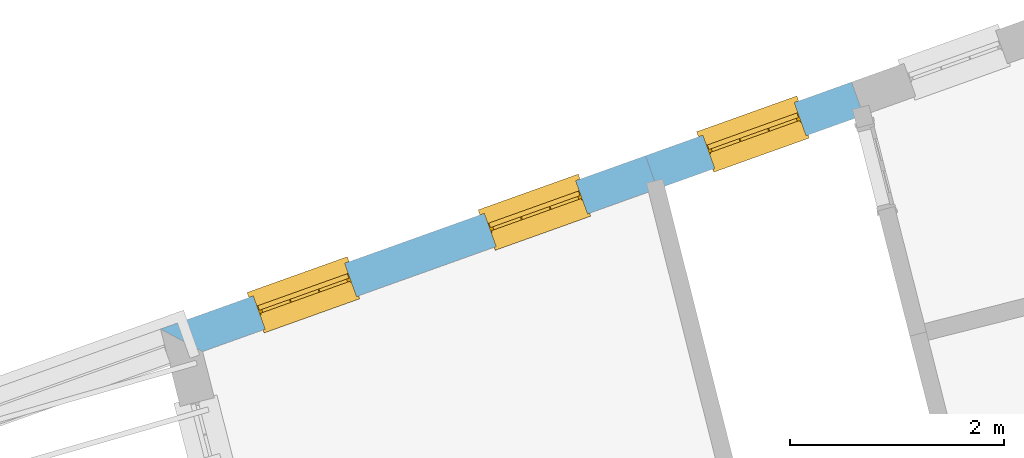
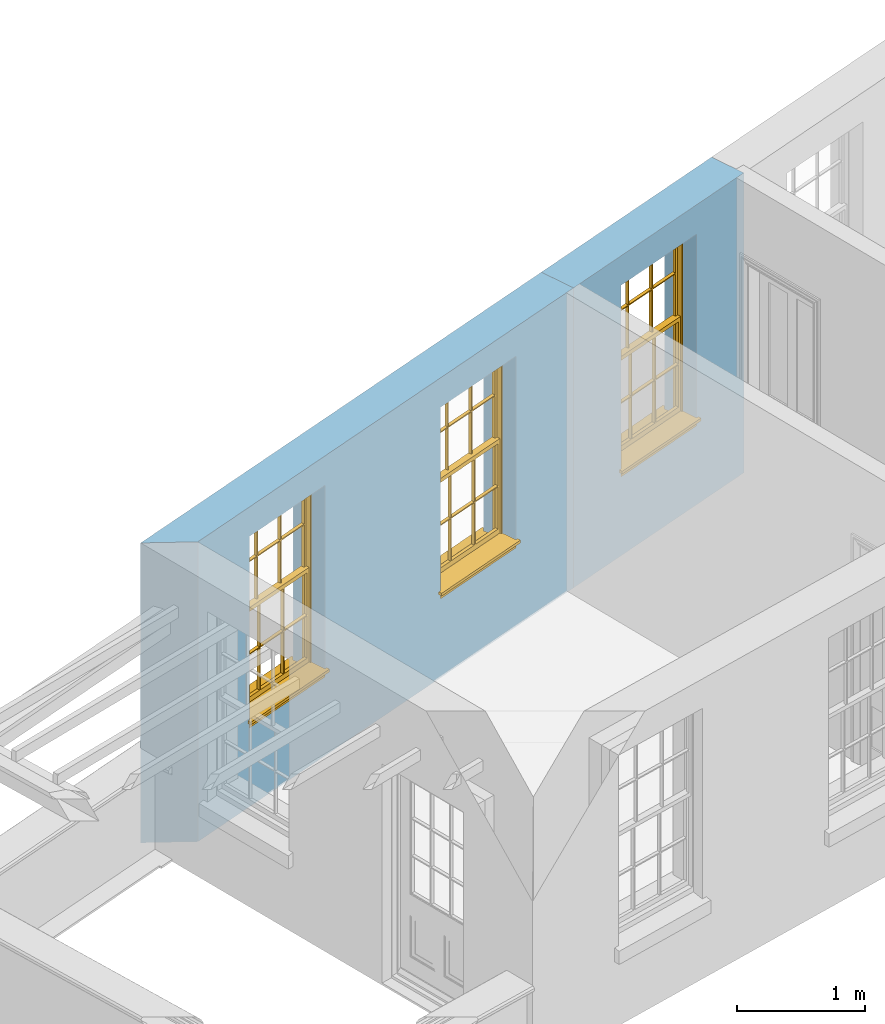
# One storey, part 4 of 11: 3 windows, 3 openings, plus 2 elements that do not belong to this part.
"""IFC2X3 building model written with IfcOpenShell, lengths in metres."""

from ifc_helpers import new_model, si_unit, frame, origin, place, context, subcontext, project, spatial, polyline, outline, extrude, faceted_brep, material, layer, layer_set, layer_usage, element, fill, save


model = new_model("IFC2X3")

# Units and contexts
model_context = context("Model", 3, world=origin())
body_context = subcontext(model_context, "Body", "Model", "MODEL_VIEW")
ifc_project = project(units=[si_unit("PLANEANGLEUNIT", "RADIAN"), si_unit("MASSUNIT", "GRAM", prefix="KILO"), si_unit("FORCEUNIT", "NEWTON", prefix="KILO"), si_unit("LENGTHUNIT", "METRE")], contexts=[model_context])

# Site, building, storey
site_placement = place(None, origin())
site = spatial("IfcSite", under=ifc_project, at=site_placement, CompositionType="ELEMENT")
building_placement = place(None, origin())
building = spatial("IfcBuilding", under=site, at=building_placement, Name="Building plot-13", CompositionType="ELEMENT")
storey_placement = place(None, frame((0.0, 0.0, 6.7)))
storey = spatial("IfcBuildingStorey", under=building, at=storey_placement, Name="Floor 1", CompositionType="ELEMENT", Elevation=6.7)

# Wall, opening, window
ifc_material = material(Name="Masonry")
ifc_layer = layer(ifc_material, 0.33, ventilated=False)
ifc_layer_set = layer_set([ifc_layer], Name="My Wall")
ifc_layer_usage = layer_usage(ifc_layer_set, "AXIS2", "NEGATIVE", 0.08)
wall_1_placement = place(storey_placement, origin())
wall_1 = element("IfcWallStandardCase", 1, at=wall_1_placement, inside=storey, material=ifc_layer_usage, Name="exterior", context=body_context, shape_type="SweptSolid", body=[
    extrude(outline(polyline([(72.090338058868, 49.7513205451126), (71.9792289491637, 50.0620531725284), (70.0510857180657, 49.3726042415572), (70.16219482777, 49.0618716141414), (72.090338058868, 49.7513205451126)])), origin(), (0.0, 0.0, 1.0), 2.85),
])
opening_1_placement = place(storey_placement, frame((0.0, 0.0, 0.75)))
opening_1 = element("IfcOpeningElement", 2, at=opening_1_placement, cuts=wall_1, Name="Opening", ObjectType="Opening", context=body_context, shape_type="SweptSolid", body=[
    extrude(outline(polyline([(71.4435917138395, 49.870524600726), (70.5867229533899, 49.5641328133596), (70.6978320630942, 49.2534001859438), (71.5547008235438, 49.5597919733102), (71.4435917138395, 49.870524600726)])), origin(), (0.0, 0.0, 1.0), 1.82),
])
window_1_placement = place(storey_placement, frame((71.5277652817973, 49.635121095108, 0.75), z_axis=(0.0, 0.0, 1.0), x_axis=(-0.856868760449586, -0.306391787366422, 0.0)))
window_1 = element("IfcWindow", 3, at=window_1_placement, inside=storey, Name="circulation outside window", OverallHeight=1.82, OverallWidth=0.91, context=body_context, shape_type="Brep", held_by="IfcProductRepresentation", body=[
    faceted_brep([(0.033125, -0.105, 0.975209), (0.01, -0.105, 0.975209), (0.033125, -0.105, 1.376042), (0.876875, -0.105, 0.975209), (0.876875, -0.105, 1.376042), (0.9, -0.105, 0.975209), (0.876875, -0.105, 1.386042), (0.876875, -0.105, 1.786875), (0.9, -0.105, 1.81), (0.033125, -0.105, 1.786875), (0.033125, -0.105, 1.386042), (0.01, -0.105, 1.81), (0.876875, -0.135, 1.376042), (0.876875, -0.135, 0.975209), (0.9, -0.135, 0.937083), (0.033125, -0.135, 1.786875), (0.01, -0.135, 1.81), (0.033125, -0.135, 1.386042), (0.01, -0.135, 0.937083), (0.033125, -0.135, 0.975209), (0.033125, -0.135, 1.376042), (0.876875, -0.135, 1.786875), (0.876875, -0.135, 1.386042), (0.9, -0.135, 1.81), (0.033125, -0.105, 0.937083), (0.01, -0.105, 0.937083), (0.033125, -0.105, 0.53625), (0.876875, -0.105, 0.937083), (0.876875, -0.105, 0.53625), (0.9, -0.105, 0.937083), (0.876875, -0.105, 0.52625), (0.876875, -0.105, 0.125417), (0.9, -0.105, 0.077167), (0.033125, -0.105, 0.125417), (0.033125, -0.105, 0.52625), (0.01, -0.105, 0.077167), (-0.0425, -0.25, 0.01), (-0.0425, -0.3, 0.001667), (0.0, -0.25, 0.01), (0.9525, -0.25, 0.01), (0.91, -0.25, 0.01), (0.9525, -0.3, 0.001667), (-0.02, 0.08, 0.077167), (0.0, 0.08, 0.077167), (-0.02, 0.11, 0.077167), (0.0, -0.06, 0.077167), (0.01, -0.06, 0.077167), (0.91, -0.06, 0.077167), (0.91, 0.08, 0.077167), (0.9, -0.06, 0.077167), (0.93, 0.08, 0.077167), (0.93, 0.11, 0.077167), (0.01, -0.075, 0.975209), (0.9, -0.075, 0.975209), (0.876875, -0.075, 0.125417), (0.876875, -0.075, 0.52625), (0.9, -0.075, 0.077167), (0.876875, -0.075, 0.53625), (0.876875, -0.075, 0.937083), (0.033125, -0.075, 0.125417), (0.01, -0.075, 0.077167), (0.033125, -0.075, 0.52625), (0.033125, -0.075, 0.937083), (0.033125, -0.075, 0.53625), (-0.02, 0.08, 0.052167), (-0.02, 0.11, 0.052167), (0.93, 0.11, 0.052167), (0.93, 0.08, 0.052167), (0.91, 0.08, 0.052167), (0.0, 0.08, 0.052167), (0.91, -0.15, 0.026667), (0.0, -0.15, 0.026667), (-0.0425, -0.3, -0.123333), (0.9525, -0.3, -0.123333), (-0.0425, -0.25, -0.123333), (0.9525, -0.25, -0.123333), (0.01, -0.06, 1.81), (0.9, -0.06, 1.81), (0.0, -0.06, 1.82), (0.91, -0.06, 1.82), (0.01, -0.15, 0.077167), (0.9, -0.15, 0.077167), (0.592292, -0.105, 0.125417), (0.592292, -0.075, 0.125417), (0.317708, -0.075, 0.125417), (0.317708, -0.105, 0.125417), (0.592292, -0.105, 0.53625), (0.317708, -0.105, 0.53625), (0.317708, -0.105, 0.52625), (0.592292, -0.105, 0.52625), (0.592292, -0.075, 0.53625), (0.317708, -0.075, 0.53625), (0.592292, -0.135, 1.386042), (0.592292, -0.105, 1.386042), (0.317708, -0.105, 1.386042), (0.317708, -0.135, 1.386042), (0.317708, -0.135, 1.376042), (0.592292, -0.135, 1.376042), (0.317708, -0.105, 1.376042), (0.592292, -0.105, 1.376042), (0.602292, -0.135, 1.376042), (0.592292, -0.135, 0.975209), (0.602292, -0.135, 0.975209), (0.602292, -0.105, 0.975209), (0.592292, -0.105, 0.975209), (0.602292, -0.105, 1.376042), (0.602292, -0.075, 0.53625), (0.602292, -0.105, 0.53625), (0.317708, -0.075, 0.52625), (0.307708, -0.075, 0.125417), (0.307708, -0.075, 0.52625), (0.602292, -0.075, 0.52625), (0.602292, -0.075, 0.125417), (0.592292, -0.075, 0.52625), (0.307708, -0.075, 0.53625), (0.317708, -0.075, 0.937083), (0.307708, -0.075, 0.937083), (0.602292, -0.075, 0.937083), (0.592292, -0.075, 0.937083), (0.307708, -0.105, 0.52625), (0.307708, -0.105, 0.125417), (0.307708, -0.105, 0.53625), (0.307708, -0.105, 0.937083), (0.592292, -0.105, 0.937083), (0.317708, -0.105, 0.937083), (0.602292, -0.105, 0.937083), (0.602292, -0.105, 0.52625), (0.602292, -0.105, 0.125417), (0.307708, -0.135, 1.386042), (0.307708, -0.135, 1.376042), (0.307708, -0.135, 0.975209), (0.317708, -0.135, 0.975209), (0.317708, -0.135, 1.786875), (0.307708, -0.135, 1.786875), (0.602292, -0.135, 1.786875), (0.592292, -0.135, 1.786875), (0.602292, -0.135, 1.386042), (0.602292, -0.105, 1.386042), (0.307708, -0.105, 1.386042), (0.307708, -0.105, 1.786875), (0.317708, -0.105, 1.786875), (0.592292, -0.105, 1.786875), (0.602292, -0.105, 1.786875), (0.307708, -0.105, 1.376042), (0.317708, -0.105, 0.975209), (0.307708, -0.105, 0.975209), (0.91, -0.15, 1.82), (0.9, -0.15, 1.81), (0.01, -0.15, 1.81), (0.0, -0.15, 1.82), (0.91, -0.25, 0.0), (0.0, -0.25, 0.0), (0.91, 0.08, 0.0), (0.0, 0.08, 0.0)], [[[0, 1, 2]], [[3, 4, 5]], [[6, 7, 8]], [[9, 10, 11]], [[12, 13, 14]], [[15, 16, 17]], [[18, 19, 20]], [[21, 22, 23]], [[24, 25, 26]], [[27, 28, 29]], [[30, 31, 32]], [[33, 34, 35]], [[14, 27, 29]], [[25, 24, 18]], [[36, 37, 38]], [[39, 40, 41]], [[42, 43, 44]], [[45, 46, 43]], [[47, 48, 49]], [[50, 51, 48]], [[1, 0, 52]], [[5, 53, 3]], [[54, 55, 56]], [[57, 58, 53]], [[59, 60, 61]], [[62, 63, 52]], [[48, 43, 46, 49]], [[51, 44, 43, 48]], [[64, 42, 44, 65]], [[65, 44, 51, 66]], [[66, 51, 50, 67]], [[65, 66, 68, 69]], [[60, 56, 49, 46]], [[70, 71, 38, 40]], [[37, 41, 40, 38]], [[37, 72, 73, 41]], [[74, 75, 73, 72]], [[8, 11, 76, 77]], [[76, 78, 79, 77]], [[32, 35, 80, 81]], [[81, 80, 71, 70]], [[82, 83, 84, 85]], [[86, 87, 88, 89]], [[86, 90, 91, 87]], [[92, 93, 94, 95]], [[92, 95, 96, 97]], [[96, 98, 99, 97]], [[100, 97, 101, 102]], [[103, 104, 99, 105]], [[97, 99, 104, 101]], [[102, 103, 105, 100]], [[28, 57, 106, 107]], [[108, 84, 109, 110]], [[111, 112, 83, 113]], [[114, 110, 61, 63]], [[90, 113, 108, 91]], [[115, 91, 114, 116]], [[117, 106, 90, 118]], [[111, 106, 57, 55]], [[119, 110, 109, 120]], [[34, 61, 110, 119]], [[89, 113, 83, 82]], [[88, 108, 113, 89]], [[85, 84, 108, 88]], [[121, 114, 63, 26]], [[122, 116, 114, 121]], [[123, 118, 90, 86]], [[87, 91, 115, 124]], [[107, 106, 117, 125]], [[126, 111, 55, 30]], [[127, 112, 111, 126]], [[126, 30, 28, 107]], [[88, 119, 120, 85]], [[126, 89, 82, 127]], [[125, 123, 86, 107]], [[121, 26, 34, 119]], [[124, 122, 121, 87]], [[128, 17, 20, 129]], [[96, 129, 130, 131]], [[132, 133, 128, 95]], [[134, 135, 92, 136]], [[100, 12, 22, 136]], [[137, 6, 4, 105]], [[94, 138, 139, 140]], [[137, 93, 141, 142]], [[99, 98, 94, 93]], [[143, 2, 10, 138]], [[144, 145, 143, 98]], [[129, 143, 145, 130]], [[20, 2, 143, 129]], [[131, 144, 98, 96]], [[128, 138, 10, 17]], [[133, 139, 138, 128]], [[135, 141, 93, 92]], [[95, 94, 140, 132]], [[22, 6, 137, 136]], [[136, 137, 142, 134]], [[100, 105, 4, 12]], [[107, 86, 89, 126]], [[106, 111, 113, 90]], [[91, 108, 110, 114]], [[87, 121, 119, 88]], [[97, 100, 136, 92]], [[129, 96, 95, 128]], [[98, 143, 138, 94]], [[105, 99, 93, 137]], [[131, 101, 104, 144]], [[124, 115, 118, 123]], [[132, 140, 141, 135]], [[120, 109, 59, 33]], [[15, 9, 139, 133]], [[134, 142, 7, 21]], [[31, 54, 112, 127]], [[36, 74, 72, 37]], [[39, 41, 73, 75]], [[18, 14, 101, 131]], [[23, 16, 132, 135]], [[83, 56, 60, 84]], [[52, 53, 118, 115]], [[53, 52, 144, 104]], [[11, 8, 141, 140]], [[14, 18, 124, 123]], [[2, 1, 11, 10]], [[8, 5, 4, 6]], [[57, 53, 56, 55]], [[60, 52, 63, 61]], [[26, 25, 35, 34]], [[32, 29, 28, 30]], [[14, 23, 22, 12]], [[18, 20, 17, 16]], [[19, 0, 2, 20]], [[17, 10, 9, 15]], [[12, 4, 3, 13]], [[21, 7, 6, 22]], [[27, 58, 57, 28]], [[30, 55, 54, 31]], [[33, 59, 61, 34]], [[26, 63, 62, 24]], [[5, 8, 77, 53]], [[76, 11, 1, 52]], [[46, 45, 78, 76]], [[49, 77, 79, 47]], [[70, 146, 147, 81]], [[71, 80, 148, 149]], [[19, 130, 145, 0]], [[102, 13, 3, 103]], [[116, 122, 24, 62]], [[29, 32, 81, 14]], [[80, 35, 25, 18]], [[60, 46, 76, 52]], [[77, 49, 56, 53]], [[23, 14, 81, 147]], [[16, 148, 80, 18]], [[35, 85, 120]], [[120, 33, 35]], [[127, 82, 32]], [[32, 31, 127]], [[32, 82, 85, 35]], [[102, 101, 14]], [[14, 13, 102]], [[18, 131, 130]], [[130, 19, 18]], [[134, 21, 23]], [[23, 135, 134]], [[16, 15, 133]], [[133, 132, 16]], [[11, 140, 139]], [[139, 9, 11]], [[142, 141, 8]], [[8, 7, 142]], [[23, 147, 148, 16]], [[146, 149, 148, 147]], [[52, 115, 116]], [[116, 62, 52]], [[118, 53, 117]], [[58, 117, 53]], [[27, 125, 117, 58]], [[56, 83, 112]], [[112, 54, 56]], [[109, 84, 60]], [[60, 59, 109]], [[125, 27, 14]], [[14, 123, 125]], [[122, 124, 18]], [[18, 24, 122]], [[145, 144, 52]], [[52, 0, 145]], [[103, 3, 53]], [[53, 104, 103]], [[79, 78, 149, 146]], [[78, 45, 71, 149]], [[146, 70, 47, 79]], [[150, 75, 74, 151]], [[68, 66, 67]], [[48, 68, 67, 50]], [[69, 64, 65]], [[42, 64, 69, 43]], [[69, 68, 152, 153]], [[70, 68, 48, 47]], [[150, 152, 68, 70]], [[43, 69, 71, 45]], [[69, 153, 151, 71]], [[152, 150, 151, 153]], [[38, 151, 74, 36]], [[71, 151, 38]], [[39, 75, 150, 40]], [[40, 150, 70]]]),
])
fill(opening_1, window_1)

# Wall, openings, windows
wall_2_placement = place(storey_placement, origin())
wall_2 = element("IfcWallStandardCase", 4, at=wall_2_placement, inside=storey, material=ifc_layer_usage, Name="exterior", context=body_context, shape_type="SweptSolid", body=[
    extrude(outline(polyline([(70.16219482777, 49.0618716141414), (70.0510857180657, 49.3726042415572), (65.5129266056267, 47.7498882014907), (65.9065629771408, 47.5401792508866), (70.16219482777, 49.0618716141414)])), origin(), (0.0, 0.0, 1.0), 2.85),
])
opening_2_placement = place(storey_placement, frame((0.0, 0.0, 0.75)))
opening_2 = element("IfcOpeningElement", 5, at=opening_2_placement, cuts=wall_2, Name="Opening", ObjectType="Opening", context=body_context, shape_type="SweptSolid", body=[
    extrude(outline(polyline([(69.3984892712811, 49.1392543973472), (68.5416205108315, 48.8328626099808), (68.6527296205358, 48.522129982565), (69.5095983809854, 48.8285217699314), (69.3984892712811, 49.1392543973472)])), origin(), (0.0, 0.0, 1.0), 1.82),
])
opening_3_placement = place(storey_placement, frame((0.0, 0.0, 0.75)))
opening_3 = element("IfcOpeningElement", 6, at=opening_3_placement, cuts=wall_2, Name="Opening", ObjectType="Opening", context=body_context, shape_type="SweptSolid", body=[
    extrude(outline(polyline([(67.2364276172623, 48.3661629215608), (66.3795588568127, 48.0597711341944), (66.490667966517, 47.7490385067786), (67.3475367269666, 48.055430294145), (67.2364276172623, 48.3661629215608)])), origin(), (0.0, 0.0, 1.0), 1.82),
])
window_2_placement = place(storey_placement, frame((69.4826628392389, 48.9038508917292, 0.75), z_axis=(0.0, 0.0, 1.0), x_axis=(-0.856868760449572, -0.306391787366422, 0.0)))
window_2 = element("IfcWindow", 7, at=window_2_placement, inside=storey, Name="bedroom outside window", OverallHeight=1.82, OverallWidth=0.91, context=body_context, shape_type="Brep", held_by="IfcProductRepresentation", body=[
    faceted_brep([(0.033125, -0.105, 0.975209), (0.01, -0.105, 0.975209), (0.033125, -0.105, 1.376042), (0.876875, -0.105, 0.975209), (0.876875, -0.105, 1.376042), (0.9, -0.105, 0.975209), (0.876875, -0.105, 1.386042), (0.876875, -0.105, 1.786875), (0.9, -0.105, 1.81), (0.033125, -0.105, 1.786875), (0.033125, -0.105, 1.386042), (0.01, -0.105, 1.81), (0.876875, -0.135, 1.376042), (0.876875, -0.135, 0.975209), (0.9, -0.135, 0.937083), (0.033125, -0.135, 1.786875), (0.01, -0.135, 1.81), (0.033125, -0.135, 1.386042), (0.01, -0.135, 0.937083), (0.033125, -0.135, 0.975209), (0.033125, -0.135, 1.376042), (0.876875, -0.135, 1.786875), (0.876875, -0.135, 1.386042), (0.9, -0.135, 1.81), (0.033125, -0.105, 0.937083), (0.01, -0.105, 0.937083), (0.033125, -0.105, 0.53625), (0.876875, -0.105, 0.937083), (0.876875, -0.105, 0.53625), (0.9, -0.105, 0.937083), (0.876875, -0.105, 0.52625), (0.876875, -0.105, 0.125417), (0.9, -0.105, 0.077167), (0.033125, -0.105, 0.125417), (0.033125, -0.105, 0.52625), (0.01, -0.105, 0.077167), (-0.0425, -0.25, 0.01), (-0.0425, -0.3, 0.001667), (0.0, -0.25, 0.01), (0.9525, -0.25, 0.01), (0.91, -0.25, 0.01), (0.9525, -0.3, 0.001667), (-0.02, 0.08, 0.077167), (0.0, 0.08, 0.077167), (-0.02, 0.11, 0.077167), (0.0, -0.06, 0.077167), (0.01, -0.06, 0.077167), (0.91, -0.06, 0.077167), (0.91, 0.08, 0.077167), (0.9, -0.06, 0.077167), (0.93, 0.08, 0.077167), (0.93, 0.11, 0.077167), (0.01, -0.075, 0.975209), (0.9, -0.075, 0.975209), (0.876875, -0.075, 0.125417), (0.876875, -0.075, 0.52625), (0.9, -0.075, 0.077167), (0.876875, -0.075, 0.53625), (0.876875, -0.075, 0.937083), (0.033125, -0.075, 0.125417), (0.01, -0.075, 0.077167), (0.033125, -0.075, 0.52625), (0.033125, -0.075, 0.937083), (0.033125, -0.075, 0.53625), (-0.02, 0.08, 0.052167), (-0.02, 0.11, 0.052167), (0.93, 0.11, 0.052167), (0.93, 0.08, 0.052167), (0.91, 0.08, 0.052167), (0.0, 0.08, 0.052167), (0.91, -0.15, 0.026667), (0.0, -0.15, 0.026667), (-0.0425, -0.3, -0.123333), (0.9525, -0.3, -0.123333), (-0.0425, -0.25, -0.123333), (0.9525, -0.25, -0.123333), (0.01, -0.06, 1.81), (0.9, -0.06, 1.81), (0.0, -0.06, 1.82), (0.91, -0.06, 1.82), (0.01, -0.15, 0.077167), (0.9, -0.15, 0.077167), (0.592292, -0.105, 0.125417), (0.592292, -0.075, 0.125417), (0.317708, -0.075, 0.125417), (0.317708, -0.105, 0.125417), (0.592292, -0.105, 0.53625), (0.317708, -0.105, 0.53625), (0.317708, -0.105, 0.52625), (0.592292, -0.105, 0.52625), (0.592292, -0.075, 0.53625), (0.317708, -0.075, 0.53625), (0.592292, -0.135, 1.386042), (0.592292, -0.105, 1.386042), (0.317708, -0.105, 1.386042), (0.317708, -0.135, 1.386042), (0.317708, -0.135, 1.376042), (0.592292, -0.135, 1.376042), (0.317708, -0.105, 1.376042), (0.592292, -0.105, 1.376042), (0.602292, -0.135, 1.376042), (0.592292, -0.135, 0.975209), (0.602292, -0.135, 0.975209), (0.602292, -0.105, 0.975209), (0.592292, -0.105, 0.975209), (0.602292, -0.105, 1.376042), (0.602292, -0.075, 0.53625), (0.602292, -0.105, 0.53625), (0.317708, -0.075, 0.52625), (0.307708, -0.075, 0.125417), (0.307708, -0.075, 0.52625), (0.602292, -0.075, 0.52625), (0.602292, -0.075, 0.125417), (0.592292, -0.075, 0.52625), (0.307708, -0.075, 0.53625), (0.317708, -0.075, 0.937083), (0.307708, -0.075, 0.937083), (0.602292, -0.075, 0.937083), (0.592292, -0.075, 0.937083), (0.307708, -0.105, 0.52625), (0.307708, -0.105, 0.125417), (0.307708, -0.105, 0.53625), (0.307708, -0.105, 0.937083), (0.592292, -0.105, 0.937083), (0.317708, -0.105, 0.937083), (0.602292, -0.105, 0.937083), (0.602292, -0.105, 0.52625), (0.602292, -0.105, 0.125417), (0.307708, -0.135, 1.386042), (0.307708, -0.135, 1.376042), (0.307708, -0.135, 0.975209), (0.317708, -0.135, 0.975209), (0.317708, -0.135, 1.786875), (0.307708, -0.135, 1.786875), (0.602292, -0.135, 1.786875), (0.592292, -0.135, 1.786875), (0.602292, -0.135, 1.386042), (0.602292, -0.105, 1.386042), (0.307708, -0.105, 1.386042), (0.307708, -0.105, 1.786875), (0.317708, -0.105, 1.786875), (0.592292, -0.105, 1.786875), (0.602292, -0.105, 1.786875), (0.307708, -0.105, 1.376042), (0.317708, -0.105, 0.975209), (0.307708, -0.105, 0.975209), (0.91, -0.15, 1.82), (0.9, -0.15, 1.81), (0.01, -0.15, 1.81), (0.0, -0.15, 1.82), (0.91, -0.25, 0.0), (0.0, -0.25, 0.0), (0.91, 0.08, 0.0), (0.0, 0.08, 0.0)], [[[0, 1, 2]], [[3, 4, 5]], [[6, 7, 8]], [[9, 10, 11]], [[12, 13, 14]], [[15, 16, 17]], [[18, 19, 20]], [[21, 22, 23]], [[24, 25, 26]], [[27, 28, 29]], [[30, 31, 32]], [[33, 34, 35]], [[14, 27, 29]], [[25, 24, 18]], [[36, 37, 38]], [[39, 40, 41]], [[42, 43, 44]], [[45, 46, 43]], [[47, 48, 49]], [[50, 51, 48]], [[1, 0, 52]], [[5, 53, 3]], [[54, 55, 56]], [[57, 58, 53]], [[59, 60, 61]], [[62, 63, 52]], [[48, 43, 46, 49]], [[51, 44, 43, 48]], [[64, 42, 44, 65]], [[65, 44, 51, 66]], [[66, 51, 50, 67]], [[65, 66, 68, 69]], [[60, 56, 49, 46]], [[70, 71, 38, 40]], [[37, 41, 40, 38]], [[37, 72, 73, 41]], [[74, 75, 73, 72]], [[8, 11, 76, 77]], [[76, 78, 79, 77]], [[32, 35, 80, 81]], [[81, 80, 71, 70]], [[82, 83, 84, 85]], [[86, 87, 88, 89]], [[86, 90, 91, 87]], [[92, 93, 94, 95]], [[92, 95, 96, 97]], [[96, 98, 99, 97]], [[100, 97, 101, 102]], [[103, 104, 99, 105]], [[97, 99, 104, 101]], [[102, 103, 105, 100]], [[28, 57, 106, 107]], [[108, 84, 109, 110]], [[111, 112, 83, 113]], [[114, 110, 61, 63]], [[90, 113, 108, 91]], [[115, 91, 114, 116]], [[117, 106, 90, 118]], [[111, 106, 57, 55]], [[119, 110, 109, 120]], [[34, 61, 110, 119]], [[89, 113, 83, 82]], [[88, 108, 113, 89]], [[85, 84, 108, 88]], [[121, 114, 63, 26]], [[122, 116, 114, 121]], [[123, 118, 90, 86]], [[87, 91, 115, 124]], [[107, 106, 117, 125]], [[126, 111, 55, 30]], [[127, 112, 111, 126]], [[126, 30, 28, 107]], [[88, 119, 120, 85]], [[126, 89, 82, 127]], [[125, 123, 86, 107]], [[121, 26, 34, 119]], [[124, 122, 121, 87]], [[128, 17, 20, 129]], [[96, 129, 130, 131]], [[132, 133, 128, 95]], [[134, 135, 92, 136]], [[100, 12, 22, 136]], [[137, 6, 4, 105]], [[94, 138, 139, 140]], [[137, 93, 141, 142]], [[99, 98, 94, 93]], [[143, 2, 10, 138]], [[144, 145, 143, 98]], [[129, 143, 145, 130]], [[20, 2, 143, 129]], [[131, 144, 98, 96]], [[128, 138, 10, 17]], [[133, 139, 138, 128]], [[135, 141, 93, 92]], [[95, 94, 140, 132]], [[22, 6, 137, 136]], [[136, 137, 142, 134]], [[100, 105, 4, 12]], [[107, 86, 89, 126]], [[106, 111, 113, 90]], [[91, 108, 110, 114]], [[87, 121, 119, 88]], [[97, 100, 136, 92]], [[129, 96, 95, 128]], [[98, 143, 138, 94]], [[105, 99, 93, 137]], [[131, 101, 104, 144]], [[124, 115, 118, 123]], [[132, 140, 141, 135]], [[120, 109, 59, 33]], [[15, 9, 139, 133]], [[134, 142, 7, 21]], [[31, 54, 112, 127]], [[36, 74, 72, 37]], [[39, 41, 73, 75]], [[18, 14, 101, 131]], [[23, 16, 132, 135]], [[83, 56, 60, 84]], [[52, 53, 118, 115]], [[53, 52, 144, 104]], [[11, 8, 141, 140]], [[14, 18, 124, 123]], [[2, 1, 11, 10]], [[8, 5, 4, 6]], [[57, 53, 56, 55]], [[60, 52, 63, 61]], [[26, 25, 35, 34]], [[32, 29, 28, 30]], [[14, 23, 22, 12]], [[18, 20, 17, 16]], [[19, 0, 2, 20]], [[17, 10, 9, 15]], [[12, 4, 3, 13]], [[21, 7, 6, 22]], [[27, 58, 57, 28]], [[30, 55, 54, 31]], [[33, 59, 61, 34]], [[26, 63, 62, 24]], [[5, 8, 77, 53]], [[76, 11, 1, 52]], [[46, 45, 78, 76]], [[49, 77, 79, 47]], [[70, 146, 147, 81]], [[71, 80, 148, 149]], [[19, 130, 145, 0]], [[102, 13, 3, 103]], [[116, 122, 24, 62]], [[29, 32, 81, 14]], [[80, 35, 25, 18]], [[60, 46, 76, 52]], [[77, 49, 56, 53]], [[23, 14, 81, 147]], [[16, 148, 80, 18]], [[35, 85, 120]], [[120, 33, 35]], [[127, 82, 32]], [[32, 31, 127]], [[32, 82, 85, 35]], [[102, 101, 14]], [[14, 13, 102]], [[18, 131, 130]], [[130, 19, 18]], [[134, 21, 23]], [[23, 135, 134]], [[16, 15, 133]], [[133, 132, 16]], [[11, 140, 139]], [[139, 9, 11]], [[142, 141, 8]], [[8, 7, 142]], [[23, 147, 148, 16]], [[146, 149, 148, 147]], [[52, 115, 116]], [[116, 62, 52]], [[118, 53, 117]], [[58, 117, 53]], [[27, 125, 117, 58]], [[56, 83, 112]], [[112, 54, 56]], [[109, 84, 60]], [[60, 59, 109]], [[125, 27, 14]], [[14, 123, 125]], [[122, 124, 18]], [[18, 24, 122]], [[145, 144, 52]], [[52, 0, 145]], [[103, 3, 53]], [[53, 104, 103]], [[79, 78, 149, 146]], [[78, 45, 71, 149]], [[146, 70, 47, 79]], [[150, 75, 74, 151]], [[68, 66, 67]], [[48, 68, 67, 50]], [[69, 64, 65]], [[42, 64, 69, 43]], [[69, 68, 152, 153]], [[70, 68, 48, 47]], [[150, 152, 68, 70]], [[43, 69, 71, 45]], [[69, 153, 151, 71]], [[152, 150, 151, 153]], [[38, 151, 74, 36]], [[71, 151, 38]], [[39, 75, 150, 40]], [[40, 150, 70]]]),
])
fill(opening_2, window_2)
window_3_placement = place(storey_placement, frame((67.3206011852201, 48.1307594159428, 0.75), z_axis=(0.0, 0.0, 1.0), x_axis=(-0.856868760449572, -0.306391787366422, 0.0)))
window_3 = element("IfcWindow", 8, at=window_3_placement, inside=storey, Name="bedroom outside window", OverallHeight=1.82, OverallWidth=0.91, context=body_context, shape_type="Brep", held_by="IfcProductRepresentation", body=[
    faceted_brep([(0.033125, -0.105, 0.975209), (0.01, -0.105, 0.975209), (0.033125, -0.105, 1.376042), (0.876875, -0.105, 0.975209), (0.876875, -0.105, 1.376042), (0.9, -0.105, 0.975209), (0.876875, -0.105, 1.386042), (0.876875, -0.105, 1.786875), (0.9, -0.105, 1.81), (0.033125, -0.105, 1.786875), (0.033125, -0.105, 1.386042), (0.01, -0.105, 1.81), (0.876875, -0.135, 1.376042), (0.876875, -0.135, 0.975209), (0.9, -0.135, 0.937083), (0.033125, -0.135, 1.786875), (0.01, -0.135, 1.81), (0.033125, -0.135, 1.386042), (0.01, -0.135, 0.937083), (0.033125, -0.135, 0.975209), (0.033125, -0.135, 1.376042), (0.876875, -0.135, 1.786875), (0.876875, -0.135, 1.386042), (0.9, -0.135, 1.81), (0.033125, -0.105, 0.937083), (0.01, -0.105, 0.937083), (0.033125, -0.105, 0.53625), (0.876875, -0.105, 0.937083), (0.876875, -0.105, 0.53625), (0.9, -0.105, 0.937083), (0.876875, -0.105, 0.52625), (0.876875, -0.105, 0.125417), (0.9, -0.105, 0.077167), (0.033125, -0.105, 0.125417), (0.033125, -0.105, 0.52625), (0.01, -0.105, 0.077167), (-0.0425, -0.25, 0.01), (-0.0425, -0.3, 0.001667), (0.0, -0.25, 0.01), (0.9525, -0.25, 0.01), (0.91, -0.25, 0.01), (0.9525, -0.3, 0.001667), (-0.02, 0.08, 0.077167), (0.0, 0.08, 0.077167), (-0.02, 0.11, 0.077167), (0.0, -0.06, 0.077167), (0.01, -0.06, 0.077167), (0.91, -0.06, 0.077167), (0.91, 0.08, 0.077167), (0.9, -0.06, 0.077167), (0.93, 0.08, 0.077167), (0.93, 0.11, 0.077167), (0.01, -0.075, 0.975209), (0.9, -0.075, 0.975209), (0.876875, -0.075, 0.125417), (0.876875, -0.075, 0.52625), (0.9, -0.075, 0.077167), (0.876875, -0.075, 0.53625), (0.876875, -0.075, 0.937083), (0.033125, -0.075, 0.125417), (0.01, -0.075, 0.077167), (0.033125, -0.075, 0.52625), (0.033125, -0.075, 0.937083), (0.033125, -0.075, 0.53625), (-0.02, 0.08, 0.052167), (-0.02, 0.11, 0.052167), (0.93, 0.11, 0.052167), (0.93, 0.08, 0.052167), (0.91, 0.08, 0.052167), (0.0, 0.08, 0.052167), (0.91, -0.15, 0.026667), (0.0, -0.15, 0.026667), (-0.0425, -0.3, -0.123333), (0.9525, -0.3, -0.123333), (-0.0425, -0.25, -0.123333), (0.9525, -0.25, -0.123333), (0.01, -0.06, 1.81), (0.9, -0.06, 1.81), (0.0, -0.06, 1.82), (0.91, -0.06, 1.82), (0.01, -0.15, 0.077167), (0.9, -0.15, 0.077167), (0.592292, -0.105, 0.125417), (0.592292, -0.075, 0.125417), (0.317708, -0.075, 0.125417), (0.317708, -0.105, 0.125417), (0.592292, -0.105, 0.53625), (0.317708, -0.105, 0.53625), (0.317708, -0.105, 0.52625), (0.592292, -0.105, 0.52625), (0.592292, -0.075, 0.53625), (0.317708, -0.075, 0.53625), (0.592292, -0.135, 1.386042), (0.592292, -0.105, 1.386042), (0.317708, -0.105, 1.386042), (0.317708, -0.135, 1.386042), (0.317708, -0.135, 1.376042), (0.592292, -0.135, 1.376042), (0.317708, -0.105, 1.376042), (0.592292, -0.105, 1.376042), (0.602292, -0.135, 1.376042), (0.592292, -0.135, 0.975209), (0.602292, -0.135, 0.975209), (0.602292, -0.105, 0.975209), (0.592292, -0.105, 0.975209), (0.602292, -0.105, 1.376042), (0.602292, -0.075, 0.53625), (0.602292, -0.105, 0.53625), (0.317708, -0.075, 0.52625), (0.307708, -0.075, 0.125417), (0.307708, -0.075, 0.52625), (0.602292, -0.075, 0.52625), (0.602292, -0.075, 0.125417), (0.592292, -0.075, 0.52625), (0.307708, -0.075, 0.53625), (0.317708, -0.075, 0.937083), (0.307708, -0.075, 0.937083), (0.602292, -0.075, 0.937083), (0.592292, -0.075, 0.937083), (0.307708, -0.105, 0.52625), (0.307708, -0.105, 0.125417), (0.307708, -0.105, 0.53625), (0.307708, -0.105, 0.937083), (0.592292, -0.105, 0.937083), (0.317708, -0.105, 0.937083), (0.602292, -0.105, 0.937083), (0.602292, -0.105, 0.52625), (0.602292, -0.105, 0.125417), (0.307708, -0.135, 1.386042), (0.307708, -0.135, 1.376042), (0.307708, -0.135, 0.975209), (0.317708, -0.135, 0.975209), (0.317708, -0.135, 1.786875), (0.307708, -0.135, 1.786875), (0.602292, -0.135, 1.786875), (0.592292, -0.135, 1.786875), (0.602292, -0.135, 1.386042), (0.602292, -0.105, 1.386042), (0.307708, -0.105, 1.386042), (0.307708, -0.105, 1.786875), (0.317708, -0.105, 1.786875), (0.592292, -0.105, 1.786875), (0.602292, -0.105, 1.786875), (0.307708, -0.105, 1.376042), (0.317708, -0.105, 0.975209), (0.307708, -0.105, 0.975209), (0.91, -0.15, 1.82), (0.9, -0.15, 1.81), (0.01, -0.15, 1.81), (0.0, -0.15, 1.82), (0.91, -0.25, 0.0), (0.0, -0.25, 0.0), (0.91, 0.08, 0.0), (0.0, 0.08, 0.0)], [[[0, 1, 2]], [[3, 4, 5]], [[6, 7, 8]], [[9, 10, 11]], [[12, 13, 14]], [[15, 16, 17]], [[18, 19, 20]], [[21, 22, 23]], [[24, 25, 26]], [[27, 28, 29]], [[30, 31, 32]], [[33, 34, 35]], [[14, 27, 29]], [[25, 24, 18]], [[36, 37, 38]], [[39, 40, 41]], [[42, 43, 44]], [[45, 46, 43]], [[47, 48, 49]], [[50, 51, 48]], [[1, 0, 52]], [[5, 53, 3]], [[54, 55, 56]], [[57, 58, 53]], [[59, 60, 61]], [[62, 63, 52]], [[48, 43, 46, 49]], [[51, 44, 43, 48]], [[64, 42, 44, 65]], [[65, 44, 51, 66]], [[66, 51, 50, 67]], [[65, 66, 68, 69]], [[60, 56, 49, 46]], [[70, 71, 38, 40]], [[37, 41, 40, 38]], [[37, 72, 73, 41]], [[74, 75, 73, 72]], [[8, 11, 76, 77]], [[76, 78, 79, 77]], [[32, 35, 80, 81]], [[81, 80, 71, 70]], [[82, 83, 84, 85]], [[86, 87, 88, 89]], [[86, 90, 91, 87]], [[92, 93, 94, 95]], [[92, 95, 96, 97]], [[96, 98, 99, 97]], [[100, 97, 101, 102]], [[103, 104, 99, 105]], [[97, 99, 104, 101]], [[102, 103, 105, 100]], [[28, 57, 106, 107]], [[108, 84, 109, 110]], [[111, 112, 83, 113]], [[114, 110, 61, 63]], [[90, 113, 108, 91]], [[115, 91, 114, 116]], [[117, 106, 90, 118]], [[111, 106, 57, 55]], [[119, 110, 109, 120]], [[34, 61, 110, 119]], [[89, 113, 83, 82]], [[88, 108, 113, 89]], [[85, 84, 108, 88]], [[121, 114, 63, 26]], [[122, 116, 114, 121]], [[123, 118, 90, 86]], [[87, 91, 115, 124]], [[107, 106, 117, 125]], [[126, 111, 55, 30]], [[127, 112, 111, 126]], [[126, 30, 28, 107]], [[88, 119, 120, 85]], [[126, 89, 82, 127]], [[125, 123, 86, 107]], [[121, 26, 34, 119]], [[124, 122, 121, 87]], [[128, 17, 20, 129]], [[96, 129, 130, 131]], [[132, 133, 128, 95]], [[134, 135, 92, 136]], [[100, 12, 22, 136]], [[137, 6, 4, 105]], [[94, 138, 139, 140]], [[137, 93, 141, 142]], [[99, 98, 94, 93]], [[143, 2, 10, 138]], [[144, 145, 143, 98]], [[129, 143, 145, 130]], [[20, 2, 143, 129]], [[131, 144, 98, 96]], [[128, 138, 10, 17]], [[133, 139, 138, 128]], [[135, 141, 93, 92]], [[95, 94, 140, 132]], [[22, 6, 137, 136]], [[136, 137, 142, 134]], [[100, 105, 4, 12]], [[107, 86, 89, 126]], [[106, 111, 113, 90]], [[91, 108, 110, 114]], [[87, 121, 119, 88]], [[97, 100, 136, 92]], [[129, 96, 95, 128]], [[98, 143, 138, 94]], [[105, 99, 93, 137]], [[131, 101, 104, 144]], [[124, 115, 118, 123]], [[132, 140, 141, 135]], [[120, 109, 59, 33]], [[15, 9, 139, 133]], [[134, 142, 7, 21]], [[31, 54, 112, 127]], [[36, 74, 72, 37]], [[39, 41, 73, 75]], [[18, 14, 101, 131]], [[23, 16, 132, 135]], [[83, 56, 60, 84]], [[52, 53, 118, 115]], [[53, 52, 144, 104]], [[11, 8, 141, 140]], [[14, 18, 124, 123]], [[2, 1, 11, 10]], [[8, 5, 4, 6]], [[57, 53, 56, 55]], [[60, 52, 63, 61]], [[26, 25, 35, 34]], [[32, 29, 28, 30]], [[14, 23, 22, 12]], [[18, 20, 17, 16]], [[19, 0, 2, 20]], [[17, 10, 9, 15]], [[12, 4, 3, 13]], [[21, 7, 6, 22]], [[27, 58, 57, 28]], [[30, 55, 54, 31]], [[33, 59, 61, 34]], [[26, 63, 62, 24]], [[5, 8, 77, 53]], [[76, 11, 1, 52]], [[46, 45, 78, 76]], [[49, 77, 79, 47]], [[70, 146, 147, 81]], [[71, 80, 148, 149]], [[19, 130, 145, 0]], [[102, 13, 3, 103]], [[116, 122, 24, 62]], [[29, 32, 81, 14]], [[80, 35, 25, 18]], [[60, 46, 76, 52]], [[77, 49, 56, 53]], [[23, 14, 81, 147]], [[16, 148, 80, 18]], [[35, 85, 120]], [[120, 33, 35]], [[127, 82, 32]], [[32, 31, 127]], [[32, 82, 85, 35]], [[102, 101, 14]], [[14, 13, 102]], [[18, 131, 130]], [[130, 19, 18]], [[134, 21, 23]], [[23, 135, 134]], [[16, 15, 133]], [[133, 132, 16]], [[11, 140, 139]], [[139, 9, 11]], [[142, 141, 8]], [[8, 7, 142]], [[23, 147, 148, 16]], [[146, 149, 148, 147]], [[52, 115, 116]], [[116, 62, 52]], [[118, 53, 117]], [[58, 117, 53]], [[27, 125, 117, 58]], [[56, 83, 112]], [[112, 54, 56]], [[109, 84, 60]], [[60, 59, 109]], [[125, 27, 14]], [[14, 123, 125]], [[122, 124, 18]], [[18, 24, 122]], [[145, 144, 52]], [[52, 0, 145]], [[103, 3, 53]], [[53, 104, 103]], [[79, 78, 149, 146]], [[78, 45, 71, 149]], [[146, 70, 47, 79]], [[150, 75, 74, 151]], [[68, 66, 67]], [[48, 68, 67, 50]], [[69, 64, 65]], [[42, 64, 69, 43]], [[69, 68, 152, 153]], [[70, 68, 48, 47]], [[150, 152, 68, 70]], [[43, 69, 71, 45]], [[69, 153, 151, 71]], [[152, 150, 151, 153]], [[38, 151, 74, 36]], [[71, 151, 38]], [[39, 75, 150, 40]], [[40, 150, 70]]]),
])
fill(opening_3, window_3)

save(model, "model.ifc")
